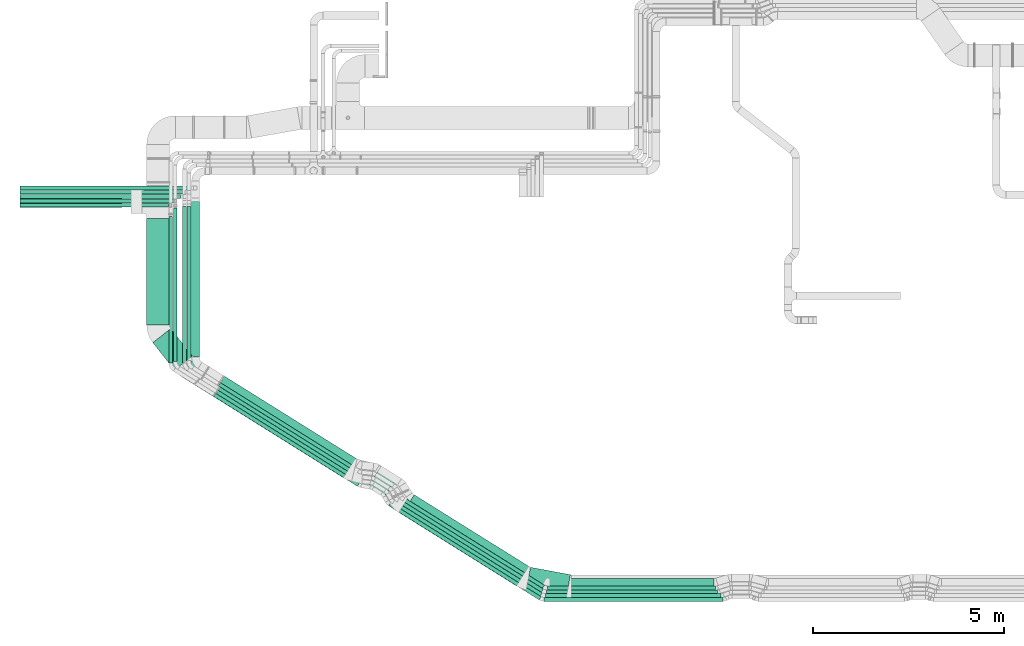
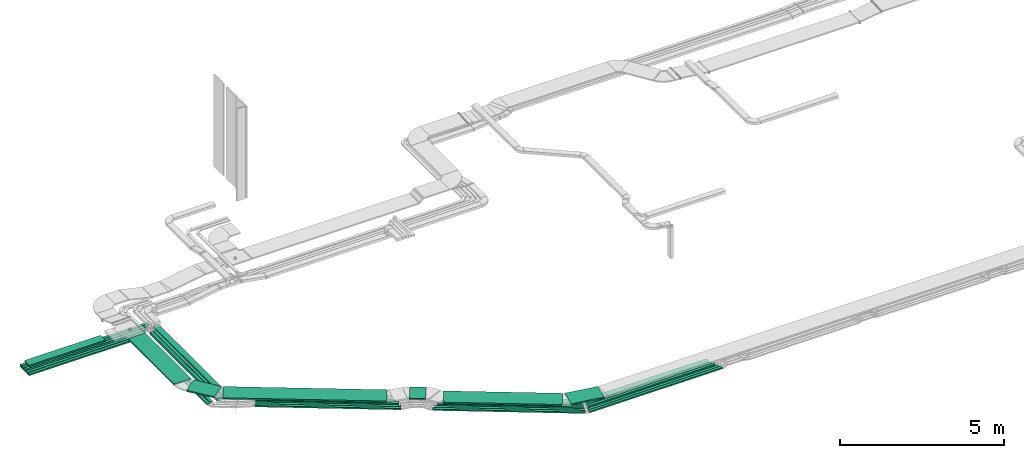
# One storey, part 1 of 38: 32 flow segments.
"""IFC2X3 building model written with IfcOpenShell, lengths in millimetres."""

from ifc_helpers import new_model, entity, si_unit, converted_unit, derived_unit, direction, frame, frame_2d, origin, origin_2d_with_axis, place, context, subcontext, project, spatial, rectangle, extrude, type_object, element, save


model = new_model("IFC2X3")

# Units and contexts
model_context = context("Model", 3, precision=0.01, world=origin(), true_north=direction((6.12303176911189e-17, 1.0)))
body_context = subcontext(model_context, "Body", "Model", "MODEL_VIEW")
ifc_project = project(units=[si_unit("LENGTHUNIT", "METRE", prefix="MILLI"), si_unit("AREAUNIT", "SQUARE_METRE"), si_unit("VOLUMEUNIT", "CUBIC_METRE"), converted_unit("PLANEANGLEUNIT", "DEGREE", entity("IfcRatioMeasure", 0.0174532925199433), si_unit("PLANEANGLEUNIT", "RADIAN"), dimensions=[0, 0, 0, 0, 0, 0, 0]), si_unit("MASSUNIT", "GRAM", prefix="KILO"), derived_unit("MASSDENSITYUNIT", [(si_unit("MASSUNIT", "GRAM", prefix="KILO"), 1), (si_unit("LENGTHUNIT", "METRE"), -3)]), derived_unit("MOMENTOFINERTIAUNIT", [(si_unit("LENGTHUNIT", "METRE"), 4)]), si_unit("TIMEUNIT", "SECOND"), si_unit("FREQUENCYUNIT", "HERTZ"), si_unit("THERMODYNAMICTEMPERATUREUNIT", "DEGREE_CELSIUS"), derived_unit("THERMALTRANSMITTANCEUNIT", [(si_unit("MASSUNIT", "GRAM", prefix="KILO"), 1), (si_unit("THERMODYNAMICTEMPERATUREUNIT", "KELVIN"), -1), (si_unit("TIMEUNIT", "SECOND"), -3)]), derived_unit("VOLUMETRICFLOWRATEUNIT", [(si_unit("LENGTHUNIT", "METRE"), 3), (si_unit("TIMEUNIT", "SECOND"), -1)]), derived_unit("MASSFLOWRATEUNIT", [(si_unit("MASSUNIT", "GRAM", prefix="KILO"), 1), (si_unit("TIMEUNIT", "SECOND"), -1)]), derived_unit("ROTATIONALFREQUENCYUNIT", [(si_unit("TIMEUNIT", "SECOND"), -1)]), si_unit("ELECTRICCURRENTUNIT", "AMPERE"), si_unit("ELECTRICVOLTAGEUNIT", "VOLT"), si_unit("POWERUNIT", "WATT"), si_unit("FORCEUNIT", "NEWTON", prefix="KILO"), si_unit("ILLUMINANCEUNIT", "LUX"), si_unit("LUMINOUSFLUXUNIT", "LUMEN"), si_unit("LUMINOUSINTENSITYUNIT", "CANDELA"), derived_unit("USERDEFINED", [(si_unit("MASSUNIT", "GRAM", prefix="KILO"), -1), (si_unit("LENGTHUNIT", "METRE"), -2), (si_unit("TIMEUNIT", "SECOND"), 3), (si_unit("LUMINOUSFLUXUNIT", "LUMEN"), 1)]), derived_unit("LINEARVELOCITYUNIT", [(si_unit("LENGTHUNIT", "METRE"), 1), (si_unit("TIMEUNIT", "SECOND"), -1)]), si_unit("PRESSUREUNIT", "PASCAL"), derived_unit("USERDEFINED", [(si_unit("LENGTHUNIT", "METRE"), -2), (si_unit("MASSUNIT", "GRAM", prefix="KILO"), 1), (si_unit("TIMEUNIT", "SECOND"), -2)]), derived_unit("LINEARFORCEUNIT", [(si_unit("MASSUNIT", "GRAM", prefix="KILO"), 1), (si_unit("LENGTHUNIT", "METRE"), 1), (si_unit("TIMEUNIT", "SECOND"), -2), (si_unit("LENGTHUNIT", "METRE"), -1)]), derived_unit("PLANARFORCEUNIT", [(si_unit("MASSUNIT", "GRAM", prefix="KILO"), 1), (si_unit("LENGTHUNIT", "METRE"), 1), (si_unit("TIMEUNIT", "SECOND"), -2), (si_unit("LENGTHUNIT", "METRE"), -2)])], contexts=[model_context])

# Site, building, storey
site_placement = place(None, frame((0.0, -0.00077364408347762, 0.0)))
site = spatial("IfcSite", under=ifc_project, at=site_placement, CompositionType="ELEMENT")
building_placement = place(site_placement, origin())
building = spatial("IfcBuilding", under=site, at=building_placement, CompositionType="ELEMENT")
storey_placement = place(building_placement, frame((0.0, 0.0, 4200.0)))
storey = spatial("IfcBuildingStorey", under=building, at=storey_placement, CompositionType="ELEMENT", Elevation=4200.0)

# Flow segments
cable_carrier_segment_type = type_object("IfcCableCarrierSegmentType", PredefinedType="CABLETRAYSEGMENT")
flow_segment_1_placement = place(storey_placement, frame((6878.59115063535, 10700.7857336441, 2760.0)))
element("IfcFlowSegment", 1, at=flow_segment_1_placement, inside=storey, type_object=cable_carrier_segment_type, context=body_context, shape_type="SweptSolid", body=[
    extrude(rectangle(XDim=4120.0, YDim=99.9999999999989, at=frame_2d((0.0, 1.08357767203415e-12), x_axis=(1.0, 0.0))), frame((2060.0, 50.0, 0.0), z_axis=(0.0, 0.0, 1.0), x_axis=(-1.0, 0.0, 0.0)), (0.0, 0.0, 1.0), 49.9999999999995),
])
flow_segment_2_placement = place(storey_placement, frame((6878.59115063535, 10590.7857336441, 2760.0)))
element("IfcFlowSegment", 2, at=flow_segment_2_placement, inside=storey, type_object=cable_carrier_segment_type, context=body_context, shape_type="SweptSolid", body=[
    extrude(rectangle(XDim=3894.99999999996, YDim=99.9999999999989, at=origin_2d_with_axis()), frame((1947.49999999998, 50.0, 0.0), z_axis=(0.0, 0.0, 1.0), x_axis=(-1.0, 0.0, 0.0)), (0.0, 0.0, 1.0), 49.9999999999995),
])
flow_segment_3_placement = place(storey_placement, frame((6878.59115063531, 10815.7857336441, 2760.0)))
element("IfcFlowSegment", 3, at=flow_segment_3_placement, inside=storey, type_object=cable_carrier_segment_type, context=body_context, shape_type="SweptSolid", body=[
    extrude(rectangle(XDim=4212.13101413564, YDim=99.9999999999989, at=frame_2d((-1.13686837721616e-12, -1.08357767203415e-12), x_axis=(1.0, 0.0))), frame((2106.06550706782, 50.0, 0.0), z_axis=(0.0, 0.0, 1.0), x_axis=(-1.0, 0.0, 0.0)), (0.0, 0.0, 1.0), 99.9999999999989),
])
flow_segment_4_placement = place(storey_placement, frame((10783.5911506353, 6496.14159813135, 2780.0)))
element("IfcFlowSegment", 4, at=flow_segment_4_placement, inside=storey, type_object=cable_carrier_segment_type, context=body_context, shape_type="SweptSolid", body=[
    extrude(rectangle(XDim=3853.03317194815, YDim=99.9999999999989, at=frame_2d((-1.02318153949454e-12, 0.0), x_axis=(1.0, 0.0))), frame((50.0, 1926.51658597408, 0.0), z_axis=(0.0, 0.0, 1.0), x_axis=(0.0, -1.0, 0.0)), (0.0, 0.0, 1.0), 49.9999999999995),
])
flow_segment_5_placement = place(storey_placement, frame((6878.5911506353, 10576.3498749111, 3110.0)))
element("IfcFlowSegment", 5, at=flow_segment_5_placement, inside=storey, type_object=cable_carrier_segment_type, context=body_context, shape_type="SweptSolid", body=[
    extrude(rectangle(XDim=2676.67085236578, YDim=300.000000000001, at=frame_2d((0.0, 1.08002495835535e-12), x_axis=(1.0, 0.0))), frame((1338.33542618289, 150.0, 0.0), z_axis=(0.0, 0.0, 1.0), x_axis=(-1.0, 0.0, 0.0)), (0.0, 0.0, 1.0), 49.9999999999984),
])
flow_segment_6_placement = place(storey_placement, frame((16923.4802752645, 585.174897497108, 2836.0)))
element("IfcFlowSegment", 6, at=flow_segment_6_placement, inside=storey, type_object=cable_carrier_segment_type, context=body_context, shape_type="SweptSolid", body=[
    extrude(rectangle(XDim=4322.88456665934, YDim=100.000000000004, at=frame_2d((-1.13686837721616e-12, -3.37507799486048e-13), x_axis=(1.0, 0.0))), frame((1859.50297654137, 1187.79230927243, 0.0), z_axis=(0.0, 0.0, 1.0), x_axis=(-0.848048096156423, 0.52991926423321, 0.0)), (0.0, 0.0, 1.0), 99.9999999999989),
])
flow_segment_7_placement = place(storey_placement, frame((16819.7699535283, 651.559918900868, 3108.85255784634)))
element("IfcFlowSegment", 7, at=flow_segment_7_placement, inside=storey, type_object=cable_carrier_segment_type, context=body_context, shape_type="SweptSolid", body=[
    extrude(rectangle(XDim=3634.71491749066, YDim=599.999999999996, at=frame_2d((5.6843418860808e-13, 1.02318153949454e-12), x_axis=(1.0, 0.0))), frame((1700.18231219462, 1217.46715623397, 0.0), z_axis=(0.0, 0.0, 1.0), x_axis=(-0.848048096156431, 0.529919264233198, 0.0)), (0.0, 0.0, 1.0), 49.9999999999995),
])
flow_segment_8_placement = place(storey_placement, frame((6878.59115063544, 11042.3068384816, 2760.0)))
element("IfcFlowSegment", 8, at=flow_segment_8_placement, inside=storey, type_object=cable_carrier_segment_type, context=body_context, shape_type="SweptSolid", body=[
    extrude(rectangle(XDim=4489.04753816118, YDim=99.9999999999989, at=frame_2d((-6.82121026329696e-13, 0.0), x_axis=(1.0, 0.0))), frame((2244.52376908059, 50.0, 0.0), z_axis=(0.0, 0.0, 1.0), x_axis=(-1.0, 0.0, 0.0)), (0.0, 0.0, 1.0), 99.9999999999989),
])
flow_segment_9_placement = place(storey_placement, frame((10903.5911506353, 6539.23906309507, 2780.0)))
element("IfcFlowSegment", 9, at=flow_segment_9_placement, inside=storey, type_object=cable_carrier_segment_type, context=body_context, shape_type="SweptSolid", body=[
    extrude(rectangle(XDim=4027.47497293644, YDim=99.9999999999989, at=frame_2d((4.54747350886464e-13, 1.08357767203415e-12), x_axis=(1.0, 0.0))), frame((50.0, 2013.73748646822, 0.0), z_axis=(0.0, 0.0, 1.0), x_axis=(0.0, -1.0, 0.0)), (0.0, 0.0, 1.0), 49.9999999999995),
])
flow_segment_10_placement = place(storey_placement, frame((17117.0382039798, 700.370087881542, 2836.0)))
element("IfcFlowSegment", 10, at=flow_segment_10_placement, inside=storey, type_object=cable_carrier_segment_type, context=body_context, shape_type="SweptSolid", body=[
    extrude(rectangle(XDim=4100.78520796288, YDim=200.000000000001, at=frame_2d((2.04636307898909e-12, 7.46069872548105e-13), x_axis=(1.0, 0.0))), frame((1791.823470603, 1171.3473497067, 0.0), z_axis=(0.0, 0.0, 1.0), x_axis=(-0.848048096156426, 0.529919264233206, 0.0)), (0.0, 0.0, 1.0), 99.9999999999989),
])
flow_segment_11_placement = place(storey_placement, frame((16773.9822900345, 485.174897497019, 2836.0)))
element("IfcFlowSegment", 11, at=flow_segment_11_placement, inside=storey, type_object=cable_carrier_segment_type, context=body_context, shape_type="SweptSolid", body=[
    extrude(rectangle(XDim=4463.65881740905, YDim=99.9999999999955, at=frame_2d((-2.27373675443232e-13, 2.02504679691629e-13), x_axis=(1.0, 0.0))), frame((1919.19464420945, 1225.09180296255, 0.0), z_axis=(0.0, 0.0, 1.0), x_axis=(-0.848048096156426, 0.529919264233206, 0.0)), (0.0, 0.0, 1.0), 99.9999999999989),
])
flow_segment_12_placement = place(storey_placement, frame((16654.152684927, 385.17489749701, 2836.0)))
element("IfcFlowSegment", 12, at=flow_segment_12_placement, inside=storey, type_object=cable_carrier_segment_type, context=body_context, shape_type="SweptSolid", body=[
    extrude(rectangle(XDim=4568.87946353609, YDim=99.9999999999957, at=frame_2d((6.82121026329696e-13, 8.10018718766514e-13), x_axis=(1.0, 0.0))), frame((1963.81072852165, 1252.97102665144, 0.0), z_axis=(0.0, 0.0, 1.0), x_axis=(-0.848048096156428, 0.529919264233203, 0.0)), (0.0, 0.0, 1.0), 49.9999999999994),
])
flow_segment_13_placement = place(storey_placement, frame((16549.0637909262, 285.174897497155, 2836.0)))
element("IfcFlowSegment", 13, at=flow_segment_13_placement, inside=storey, type_object=cable_carrier_segment_type, context=body_context, shape_type="SweptSolid", body=[
    extrude(rectangle(XDim=4658.67624033948, YDim=99.9999999999955, at=frame_2d((1.59161572810262e-12, 1.49213974509621e-12), x_axis=(1.0, 0.0))), frame((2001.8867213262, 1276.76354759852, 0.0), z_axis=(0.0, 0.0, 1.0), x_axis=(-0.848048096156427, 0.529919264233204, 0.0)), (0.0, 0.0, 1.0), 49.9999999999995),
])
flow_segment_14_placement = place(storey_placement, frame((20164.3649390053, 354.475101198491, 3108.85255784634)))
element("IfcFlowSegment", 14, at=flow_segment_14_placement, inside=storey, type_object=cable_carrier_segment_type, context=body_context, shape_type="SweptSolid", body=[
    extrude(rectangle(XDim=1067.06528774332, YDim=600.0, at=frame_2d((-2.1032064978499e-12, -4.2632564145606e-13), x_axis=(1.0, 0.0))), frame((579.379665748418, 392.467624186732, 0.0), z_axis=(0.0, 0.0, 1.0), x_axis=(0.983152914728378, -0.182784972744192, 0.0)), (0.0, 0.0, 1.0), 49.9999999999995),
])
flow_segment_15_placement = place(storey_placement, frame((11122.7644668949, 3489.33682814056, 3108.85255784634)))
element("IfcFlowSegment", 15, at=flow_segment_15_placement, inside=storey, type_object=cable_carrier_segment_type, context=body_context, shape_type="SweptSolid", body=[
    extrude(rectangle(XDim=4997.38894305518, YDim=600.0, at=frame_2d((-9.09494701772928e-13, -8.24229573481716e-13), x_axis=(1.0, 0.0))), frame((2277.98886872553, 1578.52076474239, 0.0), z_axis=(0.0, 0.0, 1.0), x_axis=(-0.84804809615643, 0.529919264233199, 0.0)), (0.0, 0.0, 1.0), 49.9999999999994),
])
flow_segment_16_placement = place(storey_placement, frame((16031.1363396529, 3009.47774082971, 3108.85255784634)))
element("IfcFlowSegment", 16, at=flow_segment_16_placement, inside=storey, type_object=cable_carrier_segment_type, context=body_context, shape_type="SweptSolid", body=[
    extrude(rectangle(XDim=503.262588776523, YDim=600.000000000001, at=frame_2d((7.53175299905706e-13, 7.95807864051312e-13), x_axis=(1.0, 0.0))), frame((372.371219409318, 387.758699227212, 0.0), z_axis=(0.0, 0.0, 1.0), x_axis=(0.848048096156357, -0.529919264233315, 0.0)), (0.0, 0.0, 1.0), 49.9999999999994),
])
flow_segment_17_placement = place(storey_placement, frame((20634.1731713098, 246.657002272001, 2836.0)))
element("IfcFlowSegment", 17, at=flow_segment_17_placement, inside=storey, type_object=cable_carrier_segment_type, context=body_context, shape_type="SweptSolid", body=[
    extrude(rectangle(XDim=4688.05213494792, YDim=100.0, at=frame_2d((0.0, 3.5527136788005e-14), x_axis=(1.0, 0.0))), frame((2344.02606747396, 50.0, 0.0)), (0.0, 0.0, 1.0), 49.9999999999995),
])
flow_segment_18_placement = place(storey_placement, frame((20663.1100797014, 346.657002271882, 2836.0)))
element("IfcFlowSegment", 18, at=flow_segment_18_placement, inside=storey, type_object=cable_carrier_segment_type, context=body_context, shape_type="SweptSolid", body=[
    extrude(rectangle(XDim=4608.58311386195, YDim=100.0, at=frame_2d((0.0, 3.19744231092045e-14), x_axis=(1.0, 0.0))), frame((2304.29155693098, 50.0, 0.0)), (0.0, 0.0, 1.0), 49.9999999999995),
])
flow_segment_19_placement = place(storey_placement, frame((20693.7075161845, 446.65700227189, 2836.0)))
element("IfcFlowSegment", 19, at=flow_segment_19_placement, inside=storey, type_object=cable_carrier_segment_type, context=body_context, shape_type="SweptSolid", body=[
    extrude(rectangle(XDim=4490.76072257844, YDim=100.0, at=frame_2d((0.0, -3.19744231092045e-14), x_axis=(1.0, 0.0))), frame((2245.38036128922, 50.0, 0.0)), (0.0, 0.0, 1.0), 99.9999999999989),
])
flow_segment_20_placement = place(storey_placement, frame((20723.8221660784, 546.657002271981, 2836.0)))
element("IfcFlowSegment", 20, at=flow_segment_20_placement, inside=storey, type_object=cable_carrier_segment_type, context=body_context, shape_type="SweptSolid", body=[
    extrude(rectangle(XDim=4410.76072257844, YDim=99.9999999999999, at=frame_2d((2.27373675443232e-12, 3.19744231092045e-14), x_axis=(1.0, 0.0))), frame((2205.38036128922, 50.0, 0.0)), (0.0, 0.0, 1.0), 99.9999999999978),
])
flow_segment_21_placement = place(storey_placement, frame((20782.021082917, 646.657002272058, 2836.0)))
element("IfcFlowSegment", 21, at=flow_segment_21_placement, inside=storey, type_object=cable_carrier_segment_type, context=body_context, shape_type="SweptSolid", body=[
    extrude(rectangle(XDim=4308.95090322303, YDim=200.0, at=frame_2d((-2.27373675443232e-12, -6.3948846218409e-14), x_axis=(1.0, 0.0))), frame((2154.47545161151, 100.0, 0.0)), (0.0, 0.0, 1.0), 99.9999999999989),
])
flow_segment_22_placement = place(storey_placement, frame((11263.5911506353, 6562.97579104635, 2779.59212886303)))
element("IfcFlowSegment", 22, at=flow_segment_22_placement, inside=storey, type_object=cable_carrier_segment_type, context=body_context, shape_type="SweptSolid", body=[
    extrude(rectangle(XDim=4044.05301703725, YDim=99.9999999999989, at=frame_2d((0.0, 1.08357767203415e-12), x_axis=(1.0, 0.0))), frame((50.0, 2022.02649883084, 0.19793414912815), z_axis=(0.0, 9.78889981381199e-05, 0.999999995208872), x_axis=(0.0, -0.999999995208872, 9.78889981381199e-05)), (0.0, 0.0, 1.0), 99.9999999999993),
])
flow_segment_23_placement = place(storey_placement, frame((11954.6144585055, 3265.38780323015, 2836.0)))
element("IfcFlowSegment", 23, at=flow_segment_23_placement, inside=storey, type_object=cable_carrier_segment_type, context=body_context, shape_type="SweptSolid", body=[
    extrude(rectangle(XDim=4452.45175223541, YDim=99.9999999999997, at=frame_2d((6.82121026329696e-13, 7.46069872548105e-13), x_axis=(1.0, 0.0))), frame((1914.44257906744, 1222.12238309705, 0.0), z_axis=(0.0, 0.0, 1.0), x_axis=(-0.848048096156423, 0.529919264233209, 0.0)), (0.0, 0.0, 1.0), 49.9999999999994),
])
flow_segment_24_placement = place(storey_placement, frame((12023.5640030035, 3351.04919574792, 2836.0)))
element("IfcFlowSegment", 24, at=flow_segment_24_placement, inside=storey, type_object=cable_carrier_segment_type, context=body_context, shape_type="SweptSolid", body=[
    extrude(rectangle(XDim=4432.32781406283, YDim=99.9999999999997, at=frame_2d((2.27373675443232e-13, -4.76063632959267e-13), x_axis=(1.0, 0.0))), frame((1905.90954534023, 1216.7903518421, 0.0), z_axis=(0.0, 0.0, 1.0), x_axis=(-0.848048096156423, 0.52991926423321, 0.0)), (0.0, 0.0, 1.0), 49.9999999999994),
])
flow_segment_25_placement = place(storey_placement, frame((12079.5922634306, 3468.51330581288, 2836.0)))
element("IfcFlowSegment", 25, at=flow_segment_25_placement, inside=storey, type_object=cable_carrier_segment_type, context=body_context, shape_type="SweptSolid", body=[
    extrude(rectangle(XDim=4369.38416435489, YDim=99.9999999999997, at=frame_2d((-6.82121026329696e-13, -8.13571432445315e-13), x_axis=(1.0, 0.0))), frame((1879.21992419025, 1200.11282557141, 0.0), z_axis=(0.0, 0.0, 1.0), x_axis=(-0.848048096156423, 0.52991926423321, 0.0)), (0.0, 0.0, 1.0), 99.9999999999989),
])
flow_segment_26_placement = place(storey_placement, frame((12082.6911146176, 3621.27024314513, 2836.0)))
element("IfcFlowSegment", 26, at=flow_segment_26_placement, inside=storey, type_object=cable_carrier_segment_type, context=body_context, shape_type="SweptSolid", body=[
    extrude(rectangle(XDim=4301.68405393387, YDim=99.9999999999992, at=frame_2d((1.13686837721616e-12, 4.05009359383257e-13), x_axis=(1.0, 0.0))), frame((1850.51344931418, 1182.17502922001, 0.0), z_axis=(0.0, 0.0, 1.0), x_axis=(-0.84804809615642, 0.529919264233215, 0.0)), (0.0, 0.0, 1.0), 99.9999999999989),
])
flow_segment_27_placement = place(storey_placement, frame((12135.9216882852, 3765.54426600308, 2836.0)))
element("IfcFlowSegment", 27, at=flow_segment_27_placement, inside=storey, type_object=cable_carrier_segment_type, context=body_context, shape_type="SweptSolid", body=[
    extrude(rectangle(XDim=4190.18160100393, YDim=199.999999999998, at=frame_2d((1.13686837721616e-12, 2.70006239588838e-13), x_axis=(1.0, 0.0))), frame((1829.72969106384, 1195.03378511941, 0.0), z_axis=(0.0, 0.0, 1.0), x_axis=(-0.848048096156421, 0.529919264233213, 0.0)), (0.0, 0.0, 1.0), 100.000000000001),
])
flow_segment_28_placement = place(storey_placement, frame((11383.5911506353, 6651.11868050194, 2780.0)))
element("IfcFlowSegment", 28, at=flow_segment_28_placement, inside=storey, type_object=cable_carrier_segment_type, context=body_context, shape_type="SweptSolid", body=[
    extrude(rectangle(XDim=4180.42273713681, YDim=200.000000000002, at=origin_2d_with_axis()), frame((100.0, 2090.21136856841, 0.0), z_axis=(0.0, 0.0, 1.0), x_axis=(0.0, 1.0, 0.0)), (0.0, 0.0, 1.0), 99.9999999999989),
])
flow_segment_29_placement = place(storey_placement, frame((10203.5911506353, 7499.26130578033, 3108.85255784625)))
element("IfcFlowSegment", 29, at=flow_segment_29_placement, inside=storey, type_object=cable_carrier_segment_type, context=body_context, shape_type="SweptSolid", body=[
    extrude(rectangle(XDim=2797.08856913082, YDim=600.000000000002, at=frame_2d((5.6843418860808e-13, 0.0), x_axis=(1.0, 0.0))), frame((300.0, 1398.54428456541, 0.0), z_axis=(0.0, 0.0, 1.0), x_axis=(0.0, -1.0, 0.0)), (0.0, 0.0, 1.0), 49.9999999999995),
])
flow_segment_30_placement = place(storey_placement, frame((10363.1987469056, 6313.1573955724, 3108.85255784634)))
element("IfcFlowSegment", 30, at=flow_segment_30_placement, inside=storey, type_object=cable_carrier_segment_type, context=body_context, shape_type="SweptSolid", body=[
    extrude(rectangle(XDim=916.95422892756, YDim=600.000000000001, at=frame_2d((-6.53699316899292e-13, -8.5265128291212e-13), x_axis=(1.0, 0.0))), frame((518.66992277584, 545.983339077736, 0.0), z_axis=(0.0, 0.0, 1.0), x_axis=(0.615661475325661, -0.78801075360672, 0.0)), (0.0, 0.0, 1.0), 49.9999999999995),
])
flow_segment_31_placement = place(storey_placement, frame((6878.59115063535, 10928.6547195084, 2760.0)))
element("IfcFlowSegment", 31, at=flow_segment_31_placement, inside=storey, type_object=cable_carrier_segment_type, context=body_context, shape_type="SweptSolid", body=[
    extrude(rectangle(XDim=4324.99999999995, YDim=99.9999999999989, at=frame_2d((6.82121026329696e-13, 1.08357767203415e-12), x_axis=(1.0, 0.0))), frame((2162.49999999998, 50.0, 0.0)), (0.0, 0.0, 1.0), 100.000000000001),
])
flow_segment_32_placement = place(storey_placement, frame((11148.5911506353, 6505.26547218254, 2780.0)))
element("IfcFlowSegment", 32, at=flow_segment_32_placement, inside=storey, type_object=cable_carrier_segment_type, context=body_context, shape_type="SweptSolid", body=[
    extrude(rectangle(XDim=4101.77848929623, YDim=99.9999999999989, at=frame_2d((-4.54747350886464e-13, 1.08357767203415e-12), x_axis=(1.0, 0.0))), frame((50.0, 2050.88924464812, 0.0), z_axis=(0.0, 0.0, 1.0), x_axis=(0.0, -1.0, 0.0)), (0.0, 0.0, 1.0), 99.9999999999989),
])

save(model, "model.ifc")
